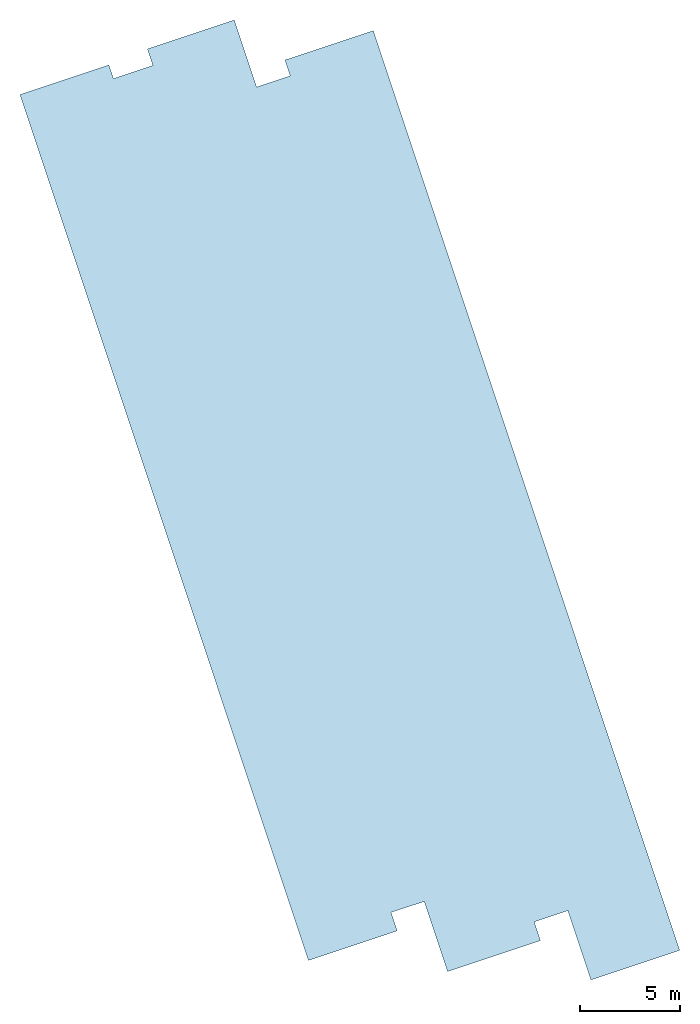
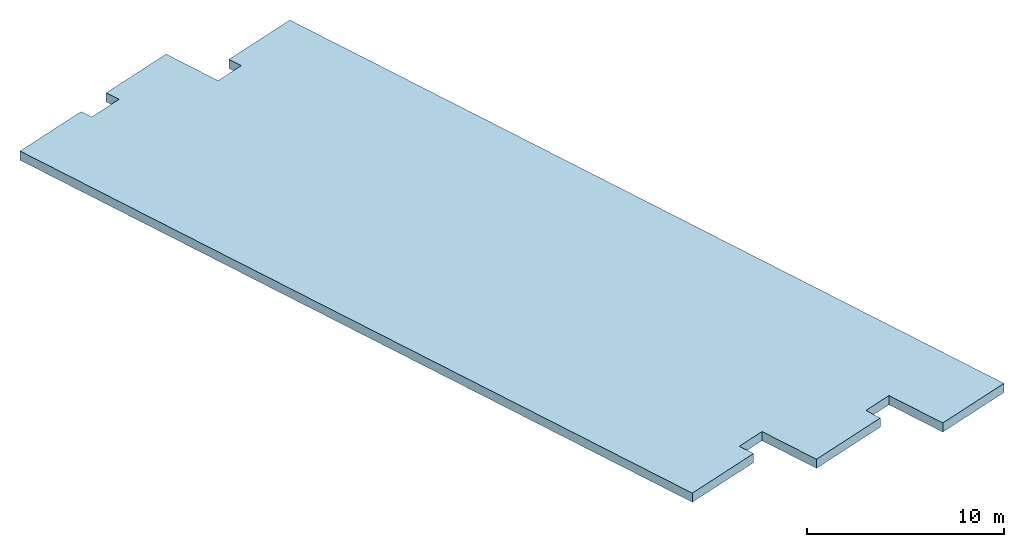
# One storey: 1 slab, 1 element without a shape of its own.
"""IFC2X3 building model written with IfcOpenShell, lengths in metres."""

import ifcopenshell
import ifcopenshell.guid

model = None  # the IFC model being written
_history = None  # IfcOwnerHistory: only IFC2X3 demands one
_inside = {}  # id of a spatial element -> (the spatial element, [elements in it])
_under = {}  # id of a project, library or spatial element -> (it, [spatial elements below it])
_declared = {}  # id of a project -> (the project, [libraries it declares])
_typed = {}  # id of a type object -> (the type object, [elements of that type])
_made_of = {}  # id of a material, layer set ... -> (it, [elements and type objects made of it])


def new_model(schema):
    """Start an empty IFC model of exactly this schema.

    Asked for "IFC4X3", IfcOpenShell would pick the latest addendum, in which some entities
    have other attributes; the version numbers below select the first issue.
    IFC2X3 requires an IfcOwnerHistory on every rooted entity: one is made here for all.
    """
    global model, _history
    if schema == "IFC4X3":
        model = ifcopenshell.file(schema_version=(4, 3, 0, 0))
    else:
        model = ifcopenshell.file(schema=schema)
    _inside.clear()
    _under.clear()
    _declared.clear()
    _typed.clear()
    _made_of.clear()
    _history = None
    if model.schema == "IFC2X3":
        org = make("IfcOrganization", Name="unknown")
        user = make(
            "IfcPersonAndOrganization",
            ThePerson=make("IfcPerson", FamilyName="unknown"),
            TheOrganization=org,
        )
        app = make(
            "IfcApplication",
            ApplicationDeveloper=org,
            Version="unknown",
            ApplicationFullName="unknown",
            ApplicationIdentifier="unknown",
        )
        _history = make(
            "IfcOwnerHistory",
            OwningUser=user,
            OwningApplication=app,
            ChangeAction="ADDED",
            CreationDate=0,
        )
    return model


def make(cls, **values):
    """One entity of the class cls with the attributes given. An attribute that is None is left unset."""
    return model.create_entity(
        cls, **{name: value for name, value in values.items() if value is not None}
    )


def entity(cls, *values):
    """Any entity or typed value of the class cls, its attributes in the order of the schema. None: left unset."""
    e = model.create_entity(cls)
    for i, value in enumerate(values):
        if value is not None:
            e[i] = value
    return e


def rooted(cls, **values):
    """An entity with a GlobalId (a new one), such as an element, a storey or a relation."""
    return make(cls, GlobalId=ifcopenshell.guid.new(), OwnerHistory=_history, **values)


def si_unit(unit_type, name, prefix=None):
    """IfcSIUnit, for example si_unit("LENGTHUNIT", "METRE", prefix="MILLI")."""
    return make("IfcSIUnit", UnitType=unit_type, Prefix=prefix, Name=name)


def converted_unit(unit_type, name, factor, base, dimensions=None, offset=None):
    """IfcConversionBasedUnit, such as the inch: factor (a typed value) times the base unit."""
    return make(
        "IfcConversionBasedUnit"
        if offset is None
        else "IfcConversionBasedUnitWithOffset",
        ConversionOffset=offset,
        Dimensions=None
        if dimensions is None
        else entity("IfcDimensionalExponents", *dimensions),
        UnitType=unit_type,
        Name=name,
        ConversionFactor=make(
            "IfcMeasureWithUnit", ValueComponent=factor, UnitComponent=base
        ),
    )


def derived_unit(unit_type, elements):
    """IfcDerivedUnit: a product of units, each with its exponent."""
    return make(
        "IfcDerivedUnit",
        Elements=[
            make("IfcDerivedUnitElement", Unit=unit, Exponent=power)
            for unit, power in elements
        ],
        UnitType=unit_type,
    )


def assignment(units):
    """IfcUnitAssignment: the units of a project."""
    return None if units is None else make("IfcUnitAssignment", Units=units)


def point(xyz):
    """IfcCartesianPoint."""
    return None if xyz is None else make("IfcCartesianPoint", Coordinates=xyz)


def direction(xyz):
    """IfcDirection."""
    return None if xyz is None else make("IfcDirection", DirectionRatios=xyz)


def frame(location, z_axis=None, x_axis=None):
    """IfcAxis2Placement3D, a coordinate frame: its origin and axes. An axis left out is left unset."""
    return make(
        "IfcAxis2Placement3D",
        Location=point(location),
        Axis=direction(z_axis),
        RefDirection=direction(x_axis),
    )


def origin():
    """The frame at (0, 0, 0) with its axes left unset."""
    return frame((0.0, 0.0, 0.0))


def place(relative_to, where):
    """IfcLocalPlacement: puts the frame where relative to a parent placement (None: the world)."""
    return make(
        "IfcLocalPlacement", PlacementRelTo=relative_to, RelativePlacement=where
    )


def context(
    kind, dimensions, precision=None, world=None, true_north=None, identifier=None
):
    """IfcGeometricRepresentationContext, for example the 3D "Model" context."""
    return make(
        "IfcGeometricRepresentationContext",
        ContextIdentifier=identifier,
        ContextType=kind,
        CoordinateSpaceDimension=dimensions,
        Precision=precision,
        WorldCoordinateSystem=world,
        TrueNorth=true_north,
    )


def subcontext(parent, identifier, kind, view, scale=None):
    """IfcGeometricRepresentationSubContext, for example "Body" below "Model"."""
    return make(
        "IfcGeometricRepresentationSubContext",
        ContextIdentifier=identifier,
        ContextType=kind,
        ParentContext=parent,
        TargetScale=scale,
        TargetView=view,
    )


def project(units=None, contexts=None):
    """IfcProject with its units and contexts."""
    return rooted(
        "IfcProject",
        Name="project",
        RepresentationContexts=contexts,
        UnitsInContext=assignment(units),
    )


def spatial(cls, under=None, at=None, **own):
    """A site, building, storey or space (cls), placed at a placement, below another one or the project."""
    s = rooted(cls, ObjectPlacement=at, **own)
    if under is not None:
        _under.setdefault(under.id(), (under, []))[1].append(s)
    return s


def polyline(points):
    """IfcPolyline through the points."""
    return make("IfcPolyline", Points=[point(p) for p in points])


def outline(outer, holes=None, kind="AREA"):
    """IfcArbitraryClosedProfileDef: a profile drawn as a closed curve; with holes, ...WithVoids."""
    if holes is None:
        return make("IfcArbitraryClosedProfileDef", ProfileType=kind, OuterCurve=outer)
    return make(
        "IfcArbitraryProfileDefWithVoids",
        ProfileType=kind,
        OuterCurve=outer,
        InnerCurves=holes,
    )


def extrude(swept, where, along, depth):
    """IfcExtrudedAreaSolid: the profile swept, set in the frame where, extruded along a direction by depth."""
    return make(
        "IfcExtrudedAreaSolid",
        SweptArea=swept,
        Position=where,
        ExtrudedDirection=direction(along),
        Depth=depth,
    )


def shape(context_of_items, identifier, shape_type, items):
    """IfcShapeRepresentation: the items that make up one representation, for example the "Body"."""
    return make(
        "IfcShapeRepresentation",
        ContextOfItems=context_of_items,
        RepresentationIdentifier=identifier,
        RepresentationType=shape_type,
        Items=items,
    )


def material(Name=None, Category=None):
    """IfcMaterial."""
    return make("IfcMaterial", Name=Name, Category=Category)


def layer(
    of_material, thickness, ventilated=None, Name=None, Category=None, Priority=None
):
    """IfcMaterialLayer: one layer of a wall or slab, of a material (None: an air gap)."""
    return make(
        "IfcMaterialLayer",
        Material=of_material,
        LayerThickness=thickness,
        IsVentilated=ventilated,
        Name=Name,
        Category=Category,
        Priority=Priority,
    )


def layer_set(layers, Name=None):
    """IfcMaterialLayerSet."""
    return make("IfcMaterialLayerSet", MaterialLayers=layers, LayerSetName=Name)


def made_of(thing, what):
    """Note that an element or type object is made of a material, layer set ...; save() writes the relation."""
    if what is not None:
        _made_of.setdefault(what.id(), (what, []))[1].append(thing)
    return thing


def type_object(cls, material=None, **own):
    """A type object (cls), such as IfcWallType, which elements share."""
    return made_of(rooted(cls, **own), material)


def element(
    cls,
    number,
    at=None,
    inside=None,
    cuts=None,
    type_object=None,
    material=None,
    context=None,
    identifier="Body",
    shape_type=None,
    held_by="IfcProductDefinitionShape",
    body=None,
    shapes=None,
    **own,
):
    """One element of the class cls, such as IfcWall. Its Tag is "e" and its number.

    at: its placement. inside: the storey or other place that contains it. cuts: it is an
    opening in that element (IfcRelVoidsElement). A single representation is given by context,
    identifier, shape_type and body (its items); several are given by shapes. held_by: the class
    of the entity that holds the representations. save() writes the other relations.
    """
    e = rooted(cls, Tag="e%d" % number, ObjectPlacement=at, **own)
    if body is not None:
        shapes = [shape(context, identifier, shape_type, body)]
    if shapes is not None:
        e.Representation = make(held_by, Representations=shapes)
    if inside is not None:
        _inside.setdefault(inside.id(), (inside, []))[1].append(e)
    if cuts is not None:
        rooted(
            "IfcRelVoidsElement", RelatingBuildingElement=cuts, RelatedOpeningElement=e
        )
    if type_object is not None:
        _typed.setdefault(type_object.id(), (type_object, []))[1].append(e)
    return made_of(e, material)


def aggregate(whole, parts):
    """IfcRelAggregates: a whole, such as a stair, and the parts it consists of."""
    return rooted("IfcRelAggregates", RelatingObject=whole, RelatedObjects=parts)


def save(model, path):
    """Write the relations noted so far, then the file.

    IfcRelAggregates (storeys below a building ...), IfcRelContainedInSpatialStructure (elements
    in a storey), IfcRelDefinesByType, IfcRelAssociatesMaterial and IfcRelDeclares: one each for
    every whole, place, type object, material and project.
    """
    for whole, parts in _under.values():
        aggregate(whole, parts)
    for where, things in _inside.values():
        rooted(
            "IfcRelContainedInSpatialStructure",
            RelatedElements=things,
            RelatingStructure=where,
        )
    for kind, things in _typed.values():
        rooted("IfcRelDefinesByType", RelatedObjects=things, RelatingType=kind)
    for what, things in _made_of.values():
        rooted("IfcRelAssociatesMaterial", RelatedObjects=things, RelatingMaterial=what)
    for by, libraries in _declared.values():
        rooted("IfcRelDeclares", RelatingContext=by, RelatedDefinitions=libraries)
    model.write(path)


model = new_model("IFC2X3")

# Units and contexts
model_context = context("Model", 3, precision=1e-05, world=origin(), true_north=direction((6.123031769111886e-17, 1.0)))
body_context = subcontext(model_context, "Body", "Model", "MODEL_VIEW")
ifc_project = project(units=[si_unit("LENGTHUNIT", "METRE"), si_unit("AREAUNIT", "SQUARE_METRE"), si_unit("VOLUMEUNIT", "CUBIC_METRE"), converted_unit("PLANEANGLEUNIT", "DEGREE", entity("IfcRatioMeasure", 0.017453292519943278), si_unit("PLANEANGLEUNIT", "RADIAN"), dimensions=[0, 0, 0, 0, 0, 0, 0]), si_unit("MASSUNIT", "GRAM", prefix="KILO"), derived_unit("MASSDENSITYUNIT", [(si_unit("MASSUNIT", "GRAM", prefix="KILO"), 1), (si_unit("LENGTHUNIT", "METRE"), -3)]), derived_unit("IONCONCENTRATIONUNIT", [(si_unit("MASSUNIT", "GRAM", prefix="KILO"), 1), (si_unit("LENGTHUNIT", "METRE"), -3)]), derived_unit("MOMENTOFINERTIAUNIT", [(si_unit("LENGTHUNIT", "METRE"), 4)]), si_unit("TIMEUNIT", "SECOND"), si_unit("FREQUENCYUNIT", "HERTZ"), si_unit("THERMODYNAMICTEMPERATUREUNIT", "DEGREE_CELSIUS"), derived_unit("THERMALTRANSMITTANCEUNIT", [(si_unit("MASSUNIT", "GRAM", prefix="KILO"), 1), (si_unit("THERMODYNAMICTEMPERATUREUNIT", "KELVIN"), -1), (si_unit("TIMEUNIT", "SECOND"), -3)]), derived_unit("THERMALCONDUCTANCEUNIT", [(si_unit("MASSUNIT", "GRAM", prefix="KILO"), 1), (si_unit("THERMODYNAMICTEMPERATUREUNIT", "KELVIN"), -1), (si_unit("TIMEUNIT", "SECOND"), -3), (si_unit("LENGTHUNIT", "METRE"), 1)]), derived_unit("VOLUMETRICFLOWRATEUNIT", [(si_unit("LENGTHUNIT", "METRE"), 3), (si_unit("TIMEUNIT", "SECOND"), -1)]), derived_unit("MASSFLOWRATEUNIT", [(si_unit("MASSUNIT", "GRAM", prefix="KILO"), 1), (si_unit("TIMEUNIT", "SECOND"), -1)]), derived_unit("ROTATIONALFREQUENCYUNIT", [(si_unit("TIMEUNIT", "SECOND"), -1)]), si_unit("ELECTRICCURRENTUNIT", "AMPERE"), si_unit("ELECTRICVOLTAGEUNIT", "VOLT"), si_unit("POWERUNIT", "WATT"), si_unit("FORCEUNIT", "NEWTON", prefix="KILO"), si_unit("ILLUMINANCEUNIT", "LUX"), si_unit("LUMINOUSFLUXUNIT", "LUMEN"), si_unit("LUMINOUSINTENSITYUNIT", "CANDELA"), derived_unit("USERDEFINED", [(si_unit("MASSUNIT", "GRAM", prefix="KILO"), -1), (si_unit("LENGTHUNIT", "METRE"), -2), (si_unit("TIMEUNIT", "SECOND"), 3), (si_unit("LUMINOUSFLUXUNIT", "LUMEN"), 1)]), derived_unit("USERDEFINED", [(si_unit("MASSUNIT", "GRAM", prefix="KILO"), 1), (si_unit("TIMEUNIT", "SECOND"), -3), (si_unit("LENGTHUNIT", "METRE"), 3), (si_unit("ELECTRICCURRENTUNIT", "AMPERE"), -2)]), derived_unit("SOUNDPOWERUNIT", [(si_unit("MASSUNIT", "GRAM", prefix="KILO"), 1), (si_unit("TIMEUNIT", "SECOND"), -3), (si_unit("LENGTHUNIT", "METRE"), 2)]), derived_unit("SOUNDPRESSUREUNIT", [(si_unit("MASSUNIT", "GRAM", prefix="KILO"), 1), (si_unit("LENGTHUNIT", "METRE"), -1), (si_unit("TIMEUNIT", "SECOND"), -2)]), derived_unit("LINEARVELOCITYUNIT", [(si_unit("LENGTHUNIT", "METRE"), 1), (si_unit("TIMEUNIT", "SECOND"), -1)]), si_unit("PRESSUREUNIT", "PASCAL"), derived_unit("USERDEFINED", [(si_unit("MASSUNIT", "GRAM", prefix="KILO"), 1), (si_unit("LENGTHUNIT", "METRE"), -2), (si_unit("TIMEUNIT", "SECOND"), -2)]), derived_unit("LINEARFORCEUNIT", [(si_unit("MASSUNIT", "GRAM", prefix="KILO"), 1), (si_unit("TIMEUNIT", "SECOND"), -2)]), derived_unit("PLANARFORCEUNIT", [(si_unit("MASSUNIT", "GRAM", prefix="KILO"), 1), (si_unit("LENGTHUNIT", "METRE"), -1), (si_unit("TIMEUNIT", "SECOND"), -2)]), derived_unit("SPECIFICHEATCAPACITYUNIT", [(si_unit("THERMODYNAMICTEMPERATUREUNIT", "KELVIN"), -1), (si_unit("LENGTHUNIT", "METRE"), 2), (si_unit("TIMEUNIT", "SECOND"), -2)]), derived_unit("HEATINGVALUEUNIT", [(si_unit("LENGTHUNIT", "METRE"), 2), (si_unit("TIMEUNIT", "SECOND"), -2)]), derived_unit("VAPORPERMEABILITYUNIT", [(si_unit("LENGTHUNIT", "METRE"), -1), (si_unit("TIMEUNIT", "SECOND"), 1)]), derived_unit("DYNAMICVISCOSITYUNIT", [(si_unit("MASSUNIT", "GRAM", prefix="KILO"), 1), (si_unit("TIMEUNIT", "SECOND"), -1), (si_unit("LENGTHUNIT", "METRE"), -1)]), derived_unit("THERMALEXPANSIONCOEFFICIENTUNIT", [(si_unit("THERMODYNAMICTEMPERATUREUNIT", "KELVIN"), -1)]), derived_unit("MODULUSOFELASTICITYUNIT", [(si_unit("MASSUNIT", "GRAM", prefix="KILO"), 1), (si_unit("LENGTHUNIT", "METRE"), -1), (si_unit("TIMEUNIT", "SECOND"), -2)]), derived_unit("ISOTHERMALMOISTURECAPACITYUNIT", [(si_unit("LENGTHUNIT", "METRE"), 3), (si_unit("MASSUNIT", "GRAM", prefix="KILO"), -1)]), derived_unit("MOISTUREDIFFUSIVITYUNIT", [(si_unit("TIMEUNIT", "SECOND"), -1), (si_unit("LENGTHUNIT", "METRE"), 2)])], contexts=[model_context])

# Site, building, storey
site_placement = place(None, frame((83.18260837531514, 5.722313863433043, -0.3219974716737357), z_axis=(0.0, 0.0, 1.0), x_axis=(0.31599863684750407, -0.9487596436982969, 0.0)))
site = spatial("IfcSite", under=ifc_project, at=site_placement, CompositionType="ELEMENT")
building_placement = place(site_placement, origin())
building = spatial("IfcBuilding", under=site, at=building_placement, CompositionType="ELEMENT")
storey_placement = place(building_placement, frame((0.0, 0.0, 10.551997471673735)))
storey = spatial("IfcBuildingStorey", under=building, at=storey_placement, CompositionType="ELEMENT", Elevation=10.551997471673735)

# Roof, slab
ifc_material_1 = material()
ifc_layer_1 = layer(ifc_material_1, 0.005)
ifc_material_2 = material()
ifc_layer_2 = layer(ifc_material_2, 0.1)
ifc_layer_3 = layer(ifc_material_2, 0.1)
ifc_material_3 = material()
ifc_layer_4 = layer(ifc_material_3, 0.08)
ifc_material_4 = material()
ifc_layer_5 = layer(ifc_material_4, 0.28)
ifc_layer_set = layer_set([ifc_layer_1, ifc_layer_2, ifc_layer_3, ifc_layer_4, ifc_layer_5], Name="Basic Roof:EXT_Toiture principale_T-ext-")
roof_placement = place(storey_placement, frame((4.379230157761319, -74.35251758779218, -0.5650000000000013)))
roof = element("IfcRoof", 1, at=roof_placement, inside=storey, material=ifc_layer_set, Name="Basic Roof:EXT_Toiture principale_T-ext-", ObjectType="Basic Roof:EXT_Toiture principale_T-ext-", ShapeType="NOTDEFINED")
slab_type = type_object("IfcSlabType", Name="Basic Roof:EXT_Toiture principale_T-ext-", PredefinedType="ROOF")
slab_placement = place(roof_placement, origin())
slab = element("IfcSlab", 2, at=slab_placement, type_object=slab_type, material=ifc_layer_set, Name="Basic Roof:EXT_Toiture principale_T-ext-", ObjectType="Basic Roof:EXT_Toiture principale_T-ext-", PredefinedType="ROOF", context=body_context, shape_type="SweptSolid", body=[
    extrude(outline(polyline([(-22.92376125642939, 8.900047697560895), (-22.923761256429398, 4.230046236859997), (-22.08750677865328, 4.230046236859989), (-22.08750677865328, 2.4613768077581906), (-25.626232157632124, 2.461365691621721), (-25.626232157632124, -2.125047562376567), (-24.756232157632127, -2.125047562376567), (-24.75623215763213, -4.208706826140659), (-25.476916846145972, -4.208706826140659), (-25.476916846145976, -8.900047697560895), (20.226273339643946, -8.900047697560895), (20.226273339643946, -4.20981996015586), (19.256267842367887, -4.20981996015586), (19.256267842367887, -2.4598114473505124), (22.9562524501013, -2.4598114473505213), (22.95625245010131, 2.4401885526494826), (21.966232117941846, 2.4401885526494826), (21.966232117941846, 4.210188552649539), (25.626232157632113, 4.2102000497439835), (25.626232157632124, 8.900047697560739), (-22.92376125642939, 8.900047697560895)])), frame((25.626232157632124, 8.900047697560895, 0.0)), (0.0, 0.0, 1.0), 0.5649999999999994),
])
aggregate(roof, [slab])

save(model, "model.ifc")
